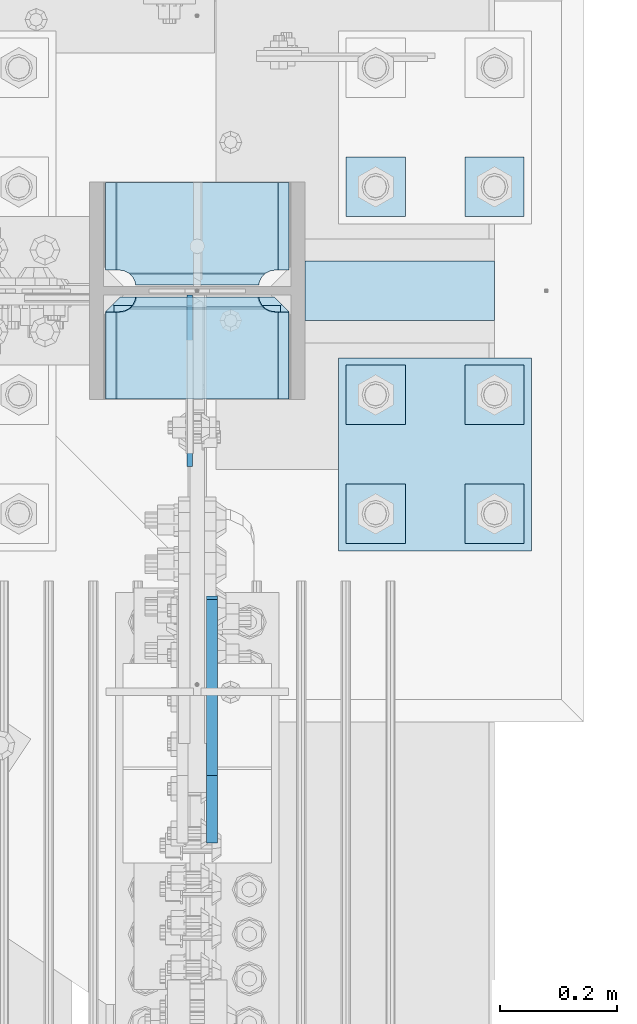
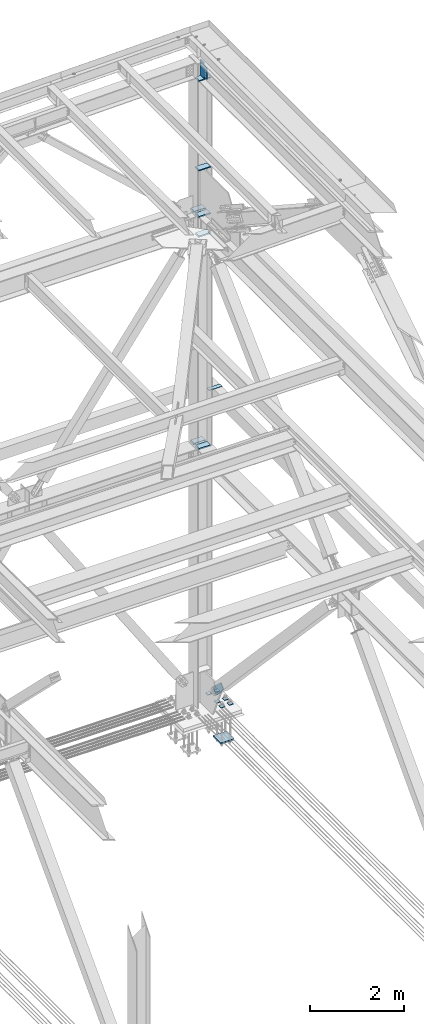
# One storey, part 3658 of 3843: 17 plates, 4 elements without a shape of their own.
"""IFC2X3 building model written with IfcOpenShell, lengths in millimetres."""

import ifcopenshell
import ifcopenshell.guid

model = None  # the IFC model being written
_history = None  # IfcOwnerHistory: only IFC2X3 demands one
_inside = {}  # id of a spatial element -> (the spatial element, [elements in it])
_under = {}  # id of a project, library or spatial element -> (it, [spatial elements below it])
_declared = {}  # id of a project -> (the project, [libraries it declares])
_typed = {}  # id of a type object -> (the type object, [elements of that type])
_made_of = {}  # id of a material, layer set ... -> (it, [elements and type objects made of it])


def new_model(schema):
    """Start an empty IFC model of exactly this schema.

    Asked for "IFC4X3", IfcOpenShell would pick the latest addendum, in which some entities
    have other attributes; the version numbers below select the first issue.
    IFC2X3 requires an IfcOwnerHistory on every rooted entity: one is made here for all.
    """
    global model, _history
    if schema == "IFC4X3":
        model = ifcopenshell.file(schema_version=(4, 3, 0, 0))
    else:
        model = ifcopenshell.file(schema=schema)
    _inside.clear()
    _under.clear()
    _declared.clear()
    _typed.clear()
    _made_of.clear()
    _history = None
    if model.schema == "IFC2X3":
        org = make("IfcOrganization", Name="unknown")
        user = make(
            "IfcPersonAndOrganization",
            ThePerson=make("IfcPerson", FamilyName="unknown"),
            TheOrganization=org,
        )
        app = make(
            "IfcApplication",
            ApplicationDeveloper=org,
            Version="unknown",
            ApplicationFullName="unknown",
            ApplicationIdentifier="unknown",
        )
        _history = make(
            "IfcOwnerHistory",
            OwningUser=user,
            OwningApplication=app,
            ChangeAction="ADDED",
            CreationDate=0,
        )
    return model


def make(cls, **values):
    """One entity of the class cls with the attributes given. An attribute that is None is left unset."""
    return model.create_entity(
        cls, **{name: value for name, value in values.items() if value is not None}
    )


def rooted(cls, **values):
    """An entity with a GlobalId (a new one), such as an element, a storey or a relation."""
    return make(cls, GlobalId=ifcopenshell.guid.new(), OwnerHistory=_history, **values)


def si_unit(unit_type, name, prefix=None):
    """IfcSIUnit, for example si_unit("LENGTHUNIT", "METRE", prefix="MILLI")."""
    return make("IfcSIUnit", UnitType=unit_type, Prefix=prefix, Name=name)


def assignment(units):
    """IfcUnitAssignment: the units of a project."""
    return None if units is None else make("IfcUnitAssignment", Units=units)


def point(xyz):
    """IfcCartesianPoint."""
    return None if xyz is None else make("IfcCartesianPoint", Coordinates=xyz)


def direction(xyz):
    """IfcDirection."""
    return None if xyz is None else make("IfcDirection", DirectionRatios=xyz)


def frame(location, z_axis=None, x_axis=None):
    """IfcAxis2Placement3D, a coordinate frame: its origin and axes. An axis left out is left unset."""
    return make(
        "IfcAxis2Placement3D",
        Location=point(location),
        Axis=direction(z_axis),
        RefDirection=direction(x_axis),
    )


def origin_with_axes():
    """The frame at (0, 0, 0) with the z axis (0, 0, 1) and the x axis (1, 0, 0) written out."""
    return frame((0.0, 0.0, 0.0), z_axis=(0.0, 0.0, 1.0), x_axis=(1.0, 0.0, 0.0))


def place(relative_to, where):
    """IfcLocalPlacement: puts the frame where relative to a parent placement (None: the world)."""
    return make(
        "IfcLocalPlacement", PlacementRelTo=relative_to, RelativePlacement=where
    )


def context(
    kind, dimensions, precision=None, world=None, true_north=None, identifier=None
):
    """IfcGeometricRepresentationContext, for example the 3D "Model" context."""
    return make(
        "IfcGeometricRepresentationContext",
        ContextIdentifier=identifier,
        ContextType=kind,
        CoordinateSpaceDimension=dimensions,
        Precision=precision,
        WorldCoordinateSystem=world,
        TrueNorth=true_north,
    )


def subcontext(parent, identifier, kind, view, scale=None):
    """IfcGeometricRepresentationSubContext, for example "Body" below "Model"."""
    return make(
        "IfcGeometricRepresentationSubContext",
        ContextIdentifier=identifier,
        ContextType=kind,
        ParentContext=parent,
        TargetScale=scale,
        TargetView=view,
    )


def project(units=None, contexts=None):
    """IfcProject with its units and contexts."""
    return rooted(
        "IfcProject",
        Name="project",
        RepresentationContexts=contexts,
        UnitsInContext=assignment(units),
    )


def spatial(cls, under=None, at=None, **own):
    """A site, building, storey or space (cls), placed at a placement, below another one or the project."""
    s = rooted(cls, ObjectPlacement=at, **own)
    if under is not None:
        _under.setdefault(under.id(), (under, []))[1].append(s)
    return s


def faces_of(points, faces, orient=None, outer=None):
    """IfcFace entities. A face is a list of loops; a loop is a list of indices into points, from 0.

    orient and outer hold one flag for each loop. By default every Orientation is true, the
    first loop of a face is its IfcFaceOuterBound and the others are IfcFaceBound.
    """
    made = []
    for i, loops in enumerate(faces):
        bounds = []
        for j, loop in enumerate(loops):
            is_outer = j == 0 if outer is None else outer[i][j]
            bounds.append(
                make(
                    "IfcFaceOuterBound" if is_outer else "IfcFaceBound",
                    Bound=make("IfcPolyLoop", Polygon=[points[k] for k in loop]),
                    Orientation=True if orient is None else orient[i][j],
                )
            )
        made.append(make("IfcFace", Bounds=bounds))
    return made


def faceted_brep(points, faces, orient=None, outer=None, voids=None):
    """IfcFacetedBrep: a solid bounded by flat faces; with voids (closed shells), ...WithVoids."""
    shared = [point(p) for p in points]
    hull = make("IfcClosedShell", CfsFaces=faces_of(shared, faces, orient, outer))
    if voids is None:
        return make("IfcFacetedBrep", Outer=hull)
    return make(
        "IfcFacetedBrepWithVoids",
        Outer=hull,
        Voids=[
            make(cls, CfsFaces=faces_of(shared, fs, o, b)) for cls, fs, o, b in voids
        ],
    )


def shape(context_of_items, identifier, shape_type, items):
    """IfcShapeRepresentation: the items that make up one representation, for example the "Body"."""
    return make(
        "IfcShapeRepresentation",
        ContextOfItems=context_of_items,
        RepresentationIdentifier=identifier,
        RepresentationType=shape_type,
        Items=items,
    )


def material(Name=None, Category=None):
    """IfcMaterial."""
    return make("IfcMaterial", Name=Name, Category=Category)


def made_of(thing, what):
    """Note that an element or type object is made of a material, layer set ...; save() writes the relation."""
    if what is not None:
        _made_of.setdefault(what.id(), (what, []))[1].append(thing)
    return thing


def type_object(cls, material=None, **own):
    """A type object (cls), such as IfcWallType, which elements share."""
    return made_of(rooted(cls, **own), material)


def element(
    cls,
    number,
    at=None,
    inside=None,
    cuts=None,
    type_object=None,
    material=None,
    context=None,
    identifier="Body",
    shape_type=None,
    held_by="IfcProductDefinitionShape",
    body=None,
    shapes=None,
    **own,
):
    """One element of the class cls, such as IfcWall. Its Tag is "e" and its number.

    at: its placement. inside: the storey or other place that contains it. cuts: it is an
    opening in that element (IfcRelVoidsElement). A single representation is given by context,
    identifier, shape_type and body (its items); several are given by shapes. held_by: the class
    of the entity that holds the representations. save() writes the other relations.
    """
    e = rooted(cls, Tag="e%d" % number, ObjectPlacement=at, **own)
    if body is not None:
        shapes = [shape(context, identifier, shape_type, body)]
    if shapes is not None:
        e.Representation = make(held_by, Representations=shapes)
    if inside is not None:
        _inside.setdefault(inside.id(), (inside, []))[1].append(e)
    if cuts is not None:
        rooted(
            "IfcRelVoidsElement", RelatingBuildingElement=cuts, RelatedOpeningElement=e
        )
    if type_object is not None:
        _typed.setdefault(type_object.id(), (type_object, []))[1].append(e)
    return made_of(e, material)


def aggregate(whole, parts):
    """IfcRelAggregates: a whole, such as a stair, and the parts it consists of."""
    return rooted("IfcRelAggregates", RelatingObject=whole, RelatedObjects=parts)


def save(model, path):
    """Write the relations noted so far, then the file.

    IfcRelAggregates (storeys below a building ...), IfcRelContainedInSpatialStructure (elements
    in a storey), IfcRelDefinesByType, IfcRelAssociatesMaterial and IfcRelDeclares: one each for
    every whole, place, type object, material and project.
    """
    for whole, parts in _under.values():
        aggregate(whole, parts)
    for where, things in _inside.values():
        rooted(
            "IfcRelContainedInSpatialStructure",
            RelatedElements=things,
            RelatingStructure=where,
        )
    for kind, things in _typed.values():
        rooted("IfcRelDefinesByType", RelatedObjects=things, RelatingType=kind)
    for what, things in _made_of.values():
        rooted("IfcRelAssociatesMaterial", RelatedObjects=things, RelatingMaterial=what)
    for by, libraries in _declared.values():
        rooted("IfcRelDeclares", RelatingContext=by, RelatedDefinitions=libraries)
    model.write(path)


model = new_model("IFC2X3")

# Units and contexts
model_context = context("Model", 3, precision=1e-05, world=origin_with_axes())
body_context = subcontext(model_context, "Body", "Model", "MODEL_VIEW")
ifc_project = project(units=[si_unit("LENGTHUNIT", "METRE", prefix="MILLI"), si_unit("AREAUNIT", "SQUARE_METRE"), si_unit("VOLUMEUNIT", "CUBIC_METRE"), si_unit("MASSUNIT", "GRAM", prefix="KILO"), si_unit("TIMEUNIT", "SECOND"), si_unit("PLANEANGLEUNIT", "RADIAN"), si_unit("SOLIDANGLEUNIT", "STERADIAN"), si_unit("THERMODYNAMICTEMPERATUREUNIT", "DEGREE_CELSIUS"), si_unit("LUMINOUSINTENSITYUNIT", "LUMEN")], contexts=[model_context])

# Site, building, storey
site_placement = place(None, origin_with_axes())
site = spatial("IfcSite", under=ifc_project, at=site_placement, CompositionType="ELEMENT")
building_placement = place(site_placement, origin_with_axes())
building = spatial("IfcBuilding", under=site, at=building_placement, Name="Undefined", CompositionType="ELEMENT")
storey_placement = place(building_placement, origin_with_axes())
storey = spatial("IfcBuildingStorey", under=building, at=storey_placement, Name="Undefined", CompositionType="ELEMENT", Elevation=0.0)

# Assembly, plate
assembly_1_placement = place(storey_placement, origin_with_axes())
assembly_1 = element("IfcElementAssembly", 1, at=assembly_1_placement, inside=storey, Name="PLATE", AssemblyPlace="NOTDEFINED", PredefinedType="RIGID_FRAME")
ifc_material_1 = material(Name="STEEL/A572-50")
plate_type_1 = type_object("IfcPlateType", PredefinedType="NOTDEFINED")
plate_1_placement = place(assembly_1_placement, frame((85832.950122492, 104508.3, 37749.1625), z_axis=(0.0, 1.0, 0.0), x_axis=(1.0, 0.0, 0.0)))
plate_1 = element("IfcPlate", 2, at=plate_1_placement, type_object=plate_type_1, material=ifc_material_1, Name="PLATE", context=body_context, shape_type="Brep", body=[
    faceted_brep([(0.0, -4.76249999999709, 0.0), (-0.000122492027003318, -4.76249999999709, 101.599998474121), (-0.000122492027003318, 4.76249999999709, 101.599998474121), (0.0, 4.76249999999709, 0.0), (323.849865722659, -4.76249999999709, 101.599998474121), (323.849865722659, 4.76249999999709, 101.599998474121), (323.849987792972, -4.76249999999709, -1.45519152283669e-11), (323.849987792972, 4.76249999999709, -1.45519152283669e-11)], [[[0, 1, 2, 3]], [[1, 4, 5, 2]], [[4, 6, 7, 5]], [[6, 0, 3, 7]], [[5, 7, 3, 2]], [[6, 4, 1, 0]]]),
])
aggregate(assembly_1, [plate_1])

# Assembly, plates
assembly_2_placement = place(storey_placement, origin_with_axes())
assembly_2 = element("IfcElementAssembly", 3, at=assembly_2_placement, inside=storey, Name="COLUMN", AssemblyPlace="NOTDEFINED", PredefinedType="RIGID_FRAME")
plate_type_2 = type_object("IfcPlateType", PredefinedType="NOTDEFINED")
plate_2_placement = place(assembly_2_placement, frame((85488.4625, 104566.24375, 42452.925), z_axis=(1.0, 0.0, 0.0), x_axis=(0.0, 1.0, 0.0)))
plate_2 = element("IfcPlate", 4, at=plate_2_placement, type_object=plate_type_2, material=ifc_material_1, Name="PLATE", context=body_context, shape_type="Brep", body=[
    faceted_brep([(16.7959640327026, 7.71646429280372, 270.56982732442), (21.5063709990791, 15.875, 275.280234290796), (21.5063709990791, 15.875, 45.3947535021725), (16.7959640327026, 7.71646429280372, 50.105160468549), (8.83016085001873, -6.0804942643299, 54.1639399157866), (3.17549995231093, -15.875, 55.0595502173092), (3.17549995231093, -15.875, 265.61543757566), (8.83016085001873, -6.0804942643299, 266.511047877182), (28.5750007629395, 15.875, 299.168629000924), (28.5750007629395, -15.875, 317.499500047692), (177.799999999999, -15.875, 317.499500047692), (177.799999999999, 15.875, 299.168629000924), (177.799999999999, 15.875, 21.5053709990898), (177.799999999999, -15.875, 3.17449995232164), (28.5750007629395, -15.875, 3.17449995232164), (28.5750007629395, 15.875, 21.5053709990898), (8.83016085001873, -15.875, 266.511047877182), (16.7959640327026, -15.875, 270.56982732442), (23.1176612314885, -15.875, 276.891524523206), (23.1176612314885, 15.875, 276.891524523206), (27.1764406787261, -15.875, 284.857327705889), (27.1764406787261, 15.875, 284.857327705889), (28.5750007629395, -15.875, 293.687488555908), (28.5750007629395, 15.875, 293.687488555908), (28.5750007629395, -15.875, 26.9874992370605), (28.5750007629395, 15.875, 26.9874992370605), (27.1764406787261, -15.875, 35.8176600870793), (27.1764406787261, 15.875, 35.8176600870793), (23.1176612314885, -15.875, 43.7834632697632), (23.1176612314885, 15.875, 43.7834632697632), (16.7959640327026, -15.875, 50.105160468549), (8.83016085001873, -15.875, 54.1639399157866)], [[[0, 1, 2, 3, 4, 5, 6, 7]], [[8, 9, 10, 11]], [[12, 13, 14, 15]], [[16, 7, 6]], [[16, 17, 0, 7]], [[17, 18, 19, 1, 0]], [[18, 20, 21, 19]], [[20, 22, 23, 21]], [[23, 22, 9, 8]], [[13, 12, 11, 10]], [[24, 25, 15, 14]], [[24, 26, 27, 25]], [[26, 28, 29, 27]], [[29, 28, 30, 3, 2]], [[30, 31, 4, 3]], [[31, 5, 4]], [[19, 21, 23, 8, 11, 12, 15, 25, 27, 29, 2, 1]], [[31, 30, 28, 26, 24, 14, 13, 10, 9, 22, 20, 18, 17, 16, 6, 5]]]),
])
plate_3_placement = place(assembly_2_placement, frame((85488.4625, 104374.15625, 41941.75), z_axis=(1.0, 0.0, 0.0), x_axis=(0.0, 1.0, 0.0)))
plate_3 = element("IfcPlate", 5, at=plate_3_placement, type_object=plate_type_2, material=ifc_material_1, Name="PLATE", context=body_context, shape_type="Brep", body=[
    faceted_brep([(161.004039019055, 7.71732501884981, 50.105160468549), (156.294129000918, 15.875, 45.3952504504123), (156.294129000918, 15.875, 275.279737342556), (161.004039019055, 7.71732501884981, 270.56982732442), (168.969842201739, -6.07963353828382, 266.511047877182), (174.625000047685, -15.875, 265.615370590487), (174.625000047685, -15.875, 55.0596294095158), (168.969842201739, -6.07963353828382, 54.1639399157866), (0.0, 15.875, 299.168629000924), (0.0, -15.875, 317.499500047692), (149.225002288818, -15.875, 317.499500047677), (149.225002288818, 15.875, 299.168629000909), (149.225002288818, 15.875, 21.5053709990752), (149.225002288818, -15.875, 3.17449995230709), (0.0, -15.875, 3.17449995232164), (0.0, 15.875, 21.5053709990898), (149.225002288818, -15.875, 293.687488555908), (149.225002288818, 15.875, 293.687488555908), (150.623562373032, -15.875, 284.857327705889), (150.623562373032, 15.875, 284.857327705889), (154.682341820269, -15.875, 276.891524523206), (154.682341820269, 15.875, 276.891524523206), (161.004039019055, -15.875, 270.56982732442), (168.969842201739, -15.875, 266.511047877182), (168.969842201739, -15.875, 54.1639399157866), (161.004039019055, -15.875, 50.105160468549), (154.682341820269, -15.875, 43.7834632697632), (154.682341820269, 15.875, 43.7834632697632), (150.623562373032, -15.875, 35.8176600870793), (150.623562373032, 15.875, 35.8176600870793), (149.225002288818, -15.875, 26.9874992370605), (149.225002288818, 15.875, 26.9874992370605)], [[[0, 1, 2, 3, 4, 5, 6, 7]], [[8, 9, 10, 11]], [[12, 13, 14, 15]], [[9, 8, 15, 14]], [[16, 17, 11, 10]], [[16, 18, 19, 17]], [[18, 20, 21, 19]], [[21, 20, 22, 3, 2]], [[22, 23, 4, 3]], [[23, 5, 4]], [[24, 7, 6]], [[24, 25, 0, 7]], [[25, 26, 27, 1, 0]], [[26, 28, 29, 27]], [[28, 30, 31, 29]], [[31, 30, 13, 12]], [[27, 29, 31, 12, 15, 8, 11, 17, 19, 21, 2, 1]], [[13, 30, 28, 26, 25, 24, 6, 5, 23, 22, 20, 18, 16, 10, 9, 14]]]),
])
plate_4_placement = place(assembly_2_placement, frame((85488.4625, 104374.15625, 42452.925), z_axis=(1.0, 0.0, 0.0), x_axis=(0.0, 1.0, 0.0)))
plate_4 = element("IfcPlate", 6, at=plate_4_placement, type_object=plate_type_2, material=ifc_material_1, Name="PLATE", context=body_context, shape_type="Brep", body=[
    faceted_brep([(161.004039019055, 7.71732501884981, 50.105160468549), (156.294129000918, 15.875, 45.3952504504123), (156.294129000918, 15.875, 275.279737342556), (161.004039019055, 7.71732501884981, 270.56982732442), (168.969842201739, -6.07963353828382, 266.511047877182), (174.625000047685, -15.875, 265.615370590487), (174.625000047685, -15.875, 55.0596294095158), (168.969842201739, -6.07963353828382, 54.1639399157866), (0.0, 15.875, 299.168629000924), (0.0, -15.875, 317.499500047692), (149.225002288818, -15.875, 317.499500047677), (149.225002288818, 15.875, 299.168629000909), (149.225002288818, 15.875, 21.5053709990752), (149.225002288818, -15.875, 3.17449995230709), (0.0, -15.875, 3.17449995232164), (0.0, 15.875, 21.5053709990898), (149.225002288818, -15.875, 293.687488555908), (149.225002288818, 15.875, 293.687488555908), (150.623562373032, -15.875, 284.857327705889), (150.623562373032, 15.875, 284.857327705889), (154.682341820269, -15.875, 276.891524523206), (154.682341820269, 15.875, 276.891524523206), (161.004039019055, -15.875, 270.56982732442), (168.969842201739, -15.875, 266.511047877182), (168.969842201739, -15.875, 54.1639399157866), (161.004039019055, -15.875, 50.105160468549), (154.682341820269, -15.875, 43.7834632697632), (154.682341820269, 15.875, 43.7834632697632), (150.623562373032, -15.875, 35.8176600870793), (150.623562373032, 15.875, 35.8176600870793), (149.225002288818, -15.875, 26.9874992370605), (149.225002288818, 15.875, 26.9874992370605)], [[[0, 1, 2, 3, 4, 5, 6, 7]], [[8, 9, 10, 11]], [[12, 13, 14, 15]], [[9, 8, 15, 14]], [[16, 17, 11, 10]], [[16, 18, 19, 17]], [[18, 20, 21, 19]], [[21, 20, 22, 3, 2]], [[22, 23, 4, 3]], [[23, 5, 4]], [[24, 7, 6]], [[24, 25, 0, 7]], [[25, 26, 27, 1, 0]], [[26, 28, 29, 27]], [[28, 30, 31, 29]], [[31, 30, 13, 12]], [[27, 29, 31, 12, 15, 8, 11, 17, 19, 21, 2, 1]], [[13, 30, 28, 26, 25, 24, 6, 5, 23, 22, 20, 18, 16, 10, 9, 14]]]),
])
plate_type_3 = type_object("IfcPlateType", PredefinedType="NOTDEFINED")
plate_5_placement = place(assembly_2_placement, frame((85490.05, 104374.15625, 45988.2875), z_axis=(1.0, 0.0, 0.0), x_axis=(0.0, 1.0, 0.0)))
plate_5 = element("IfcPlate", 7, at=plate_5_placement, type_object=plate_type_3, material=ifc_material_1, Name="PLATE", context=body_context, shape_type="Brep", body=[
    faceted_brep([(161.004039019055, 9.3046957865372, 50.105160468549), (158.127215665096, 14.2874999999985, 47.2283371145895), (158.127215665096, 14.2874999999985, 270.27166288541), (161.004039019055, 9.3046957865372, 267.394839531451), (168.969842201739, -4.49248004895344, 263.336060084213), (174.625000047683, -14.2874999999985, 262.440371073826), (174.625000047685, -14.2874999999985, 55.0596294095158), (168.969842201739, -4.49248004895344, 54.1639399157866), (0.0, 14.2874999999985, 297.827215665093), (0.0, -14.2874999999985, 314.325000047669), (149.225002288818, -14.2874999999985, 314.325000047669), (149.225002288818, 14.2874999999985, 297.827215665093), (149.225002288818, 14.2874999999985, 19.6727843348781), (149.225002288818, -14.2874999999985, 3.17499995230173), (0.0, -14.2874999999985, 3.17499995230173), (0.0, 14.2874999999985, 19.6727843348781), (149.225002288818, -14.2874999999985, 290.512500762939), (149.225002288818, 14.2874999999985, 290.512500762939), (150.623562373032, -14.2874999999985, 281.682339912921), (150.623562373032, 14.2874999999985, 281.682339912921), (154.682341820269, -14.2874999999985, 273.716536730237), (154.682341820269, 14.2874999999985, 273.716536730237), (161.004039019055, -14.2874999999985, 267.394839531451), (168.969842201739, -14.2874999999985, 263.336060084213), (168.969842201739, -14.2874999999985, 54.1639399157866), (161.004039019055, -14.2874999999985, 50.105160468549), (154.682341820269, -14.2874999999985, 43.7834632697632), (154.682341820269, 14.2874999999985, 43.7834632697632), (150.623562373032, -14.2874999999985, 35.8176600870793), (150.623562373032, 14.2874999999985, 35.8176600870793), (149.225002288818, -14.2874999999985, 26.9874992370605), (149.225002288818, 14.2874999999985, 26.9874992370605)], [[[0, 1, 2, 3, 4, 5, 6, 7]], [[8, 9, 10, 11]], [[12, 13, 14, 15]], [[15, 14, 9, 8]], [[16, 17, 11, 10]], [[16, 18, 19, 17]], [[18, 20, 21, 19]], [[21, 20, 22, 3, 2]], [[22, 23, 4, 3]], [[23, 5, 4]], [[24, 7, 6]], [[24, 25, 0, 7]], [[25, 26, 27, 1, 0]], [[26, 28, 29, 27]], [[28, 30, 31, 29]], [[31, 30, 13, 12]], [[27, 29, 31, 12, 15, 8, 11, 17, 19, 21, 2, 1]], [[13, 30, 28, 26, 25, 24, 6, 5, 23, 22, 20, 18, 16, 10, 9, 14]]]),
])
plate_type_4 = type_object("IfcPlateType", PredefinedType="NOTDEFINED")
plate_6_placement = place(assembly_2_placement, frame((85809.1375, 104744.04375, 36418.8375), z_axis=(-1.0, 0.0, 0.0), x_axis=(0.0, -1.0, 0.0)))
plate_6 = element("IfcPlate", 8, at=plate_6_placement, type_object=plate_type_4, material=ifc_material_1, Name="PLATE", context=body_context, shape_type="Brep", body=[
    faceted_brep([(161.004039019055, 6.12926429974323, 50.105160468549), (154.682341820269, 17.0787650381244, 43.7834632697632), (154.460792336729, 17.4625000000015, 43.3486479258863), (154.460792336729, 17.4625000000015, 277.326339867082), (154.682341820269, 17.0787650381244, 276.891524523206), (161.004039019055, 6.1292642997505, 270.56982732442), (168.969842201739, -7.66791153574013, 266.511047877182), (174.624750047686, -17.4625000000015, 265.615410186598), (174.624750047686, -17.4625000000015, 55.0595898134052), (168.969842201739, -7.66791153574013, 54.1639399157866), (0.0, 17.4625000000015, 297.335542336732), (0.0, -17.4625000000015, 317.499500047692), (149.225002288818, -17.4625000000015, 317.499500047663), (149.225002288818, 17.4625000000015, 297.335542336703), (149.225002288818, 17.4625000000015, 23.3394576632563), (149.225002288818, -17.4625000000015, 3.17549995229638), (0.0, -17.4625000000015, 3.17549995229638), (0.0, 17.4625000000015, 23.3394576632563), (149.225002288818, -17.4625000000015, 293.687488555908), (149.225002288818, 17.4625000000015, 293.687488555908), (150.623562373032, -17.4625000000015, 284.857327705889), (150.623562373032, 17.4625000000015, 284.857327705889), (154.682341820269, -17.4625000000015, 276.891524523206), (161.004039019055, -17.4625000000015, 270.56982732442), (168.969842201739, -17.4625000000015, 266.511047877182), (168.969842201739, -17.4625000000015, 54.1639399157866), (161.004039019055, -17.4625000000015, 50.105160468549), (154.682341820269, -17.4625000000015, 43.7834632697632), (150.623562373032, -17.4625000000015, 35.8176600870793), (150.623562373032, 17.4625000000015, 35.8176600870793), (149.225002288818, -17.4625000000015, 26.9874992370605), (149.225002288818, 17.4625000000015, 26.9874992370605)], [[[0, 1, 2, 3, 4, 5, 6, 7, 8, 9]], [[10, 11, 12, 13]], [[14, 15, 16, 17]], [[17, 16, 11, 10]], [[18, 19, 13, 12]], [[18, 20, 21, 19]], [[21, 20, 22, 4, 3]], [[22, 23, 5, 4]], [[23, 24, 6, 5]], [[24, 7, 6]], [[25, 9, 8]], [[25, 26, 0, 9]], [[26, 27, 1, 0]], [[27, 28, 29, 2, 1]], [[28, 30, 31, 29]], [[31, 30, 15, 14]], [[29, 31, 14, 17, 10, 13, 19, 21, 3, 2]], [[15, 30, 28, 27, 26, 25, 8, 7, 24, 23, 22, 20, 18, 12, 11, 16]]]),
])
plate_7_placement = place(assembly_2_placement, frame((85488.4625, 104374.15625, 36418.8375), z_axis=(1.0, 0.0, 0.0), x_axis=(0.0, 1.0, 0.0)))
plate_7 = element("IfcPlate", 9, at=plate_7_placement, type_object=plate_type_4, material=ifc_material_1, Name="PLATE", context=body_context, shape_type="Brep", body=[
    faceted_brep([(160.070930155271, 7.74588927352306, 49.8019750199746), (154.461042336727, 17.4625000000015, 44.1920872014452), (154.461042336727, 17.4625000000015, 276.482900591524), (160.070930155271, 7.74588927352306, 270.873012772994), (168.479277841048, -6.81779612594983, 266.588745638888), (174.625000047687, -17.4625000000015, 265.615358866795), (174.625000047687, -17.4625000000015, 55.0596289261739), (168.479277841048, -6.81779612594983, 54.0862421540805), (147.637502670288, 17.4625000000015, 23.3384576632816), (147.637502670288, -17.4625000000015, 3.17449995232164), (0.0, -17.4625000000015, 3.17449995232164), (0.0, 17.4625000000015, 23.3384576632816), (0.0, 17.4625000000015, 297.335542336732), (0.0, -17.4625000000015, 317.499500047692), (147.637502670288, -17.4625000000015, 317.499500047692), (147.637502670288, 17.4625000000015, 297.335542336732), (147.637502670288, -17.4625000000015, 295.274988174438), (147.637502670288, 17.4625000000015, 295.274988174438), (149.113760516208, -17.4625000000015, 285.954262963729), (149.113760516208, 17.4625000000015, 285.954262963729), (153.398027650313, -17.4625000000015, 277.545915277951), (153.398027650313, 17.4625000000015, 277.545915277951), (160.070930155271, -17.4625000000015, 270.873012772994), (168.479277841048, -17.4625000000015, 266.588745638888), (168.479277841048, -17.4625000000015, 54.0862421540805), (160.070930155271, -17.4625000000015, 49.8019750199746), (153.398027650313, -17.4625000000015, 43.1290725150175), (153.398027650313, 17.4625000000015, 43.1290725150175), (149.113760516208, -17.4625000000015, 34.7207248292398), (149.113760516208, 17.4625000000015, 34.7207248292398), (147.637502670288, -17.4625000000015, 25.3999996185303), (147.637502670288, 17.4625000000015, 25.3999996185303)], [[[0, 1, 2, 3, 4, 5, 6, 7]], [[8, 9, 10, 11]], [[12, 13, 14, 15]], [[13, 12, 11, 10]], [[16, 17, 15, 14]], [[16, 18, 19, 17]], [[18, 20, 21, 19]], [[21, 20, 22, 3, 2]], [[22, 23, 4, 3]], [[23, 5, 4]], [[24, 7, 6]], [[24, 25, 0, 7]], [[25, 26, 27, 1, 0]], [[26, 28, 29, 27]], [[28, 30, 31, 29]], [[31, 30, 9, 8]], [[27, 29, 31, 8, 11, 12, 15, 17, 19, 21, 2, 1]], [[9, 30, 28, 26, 25, 24, 6, 5, 23, 22, 20, 18, 16, 14, 13, 10]]]),
])

assembly_3_placement = place(storey_placement, origin_with_axes())
assembly_3 = element("IfcElementAssembly", 10, at=assembly_3_placement, inside=storey, Name="TEMPLATE", AssemblyPlace="NOTDEFINED", PredefinedType="RIGID_FRAME")
plate_type_5 = type_object("IfcPlateType", PredefinedType="NOTDEFINED")
plate_8_placement = place(assembly_3_placement, frame((86106.0, 104228.9, 29698.95), z_axis=(0.0, -1.0, 0.0), x_axis=(1.0, 0.0, 0.0)))
plate_8 = element("IfcPlate", 11, at=plate_8_placement, type_object=plate_type_5, material=ifc_material_1, Name="Washer Plate", context=body_context, shape_type="Brep", body=[
    faceted_brep([(0.0, -6.3499999046162, 0.0), (-1.67347025126219e-10, -6.35000000000582, 101.600000000151), (-1.67347025126219e-10, 6.35000000000582, 101.600000000151), (7.27595761418343e-12, 6.3499999046162, 0.0), (101.599998474121, -6.34999999999854, 101.599998474121), (101.599998474121, 6.34999999999854, 101.599998474121), (101.6, -6.34999999999854, 0.0), (101.6, 6.34999999999854, 0.0)], [[[0, 1, 2, 3]], [[1, 4, 5, 2]], [[4, 6, 7, 5]], [[6, 0, 3, 7]], [[5, 7, 3, 2]], [[6, 4, 1, 0]]]),
])
plate_9_placement = place(assembly_3_placement, frame((86106.0, 104432.1, 29698.95), z_axis=(0.0, -1.0, 0.0), x_axis=(1.0, 0.0, 0.0)))
plate_9 = element("IfcPlate", 12, at=plate_9_placement, type_object=plate_type_5, material=ifc_material_1, Name="Washer Plate", context=body_context, shape_type="Brep", body=[
    faceted_brep([(0.0, -6.3499999046162, 0.0), (-1.67347025126219e-10, -6.35000000000582, 101.600000000151), (-1.67347025126219e-10, 6.35000000000582, 101.600000000151), (7.27595761418343e-12, 6.3499999046162, 0.0), (101.599998474121, -6.34999999999854, 101.599998474121), (101.599998474121, 6.34999999999854, 101.599998474121), (101.6, -6.34999999999854, 0.0), (101.6, 6.34999999999854, 0.0)], [[[0, 1, 2, 3]], [[1, 4, 5, 2]], [[4, 6, 7, 5]], [[6, 0, 3, 7]], [[5, 7, 3, 2]], [[6, 4, 1, 0]]]),
])
plate_10_placement = place(assembly_3_placement, frame((86106.0, 104787.7, 29698.95), z_axis=(0.0, -1.0, 0.0), x_axis=(1.0, 0.0, 0.0)))
plate_10 = element("IfcPlate", 13, at=plate_10_placement, type_object=plate_type_5, material=ifc_material_1, Name="Washer Plate", context=body_context, shape_type="Brep", body=[
    faceted_brep([(0.0, -6.3499999046162, 0.0), (-1.67347025126219e-10, -6.35000000000582, 101.600000000151), (-1.67347025126219e-10, 6.35000000000582, 101.600000000151), (7.27595761418343e-12, 6.3499999046162, 0.0), (101.599998474121, -6.34999999999854, 101.599998474121), (101.599998474121, 6.34999999999854, 101.599998474121), (101.6, -6.34999999999854, 0.0), (101.6, 6.34999999999854, 0.0)], [[[0, 1, 2, 3]], [[1, 4, 5, 2]], [[4, 6, 7, 5]], [[6, 0, 3, 7]], [[5, 7, 3, 2]], [[6, 4, 1, 0]]]),
])
plate_11_placement = place(assembly_3_placement, frame((85902.8, 104228.9, 29698.95), z_axis=(0.0, -1.0, 0.0), x_axis=(1.0, 0.0, 0.0)))
plate_11 = element("IfcPlate", 14, at=plate_11_placement, type_object=plate_type_5, material=ifc_material_1, Name="Washer Plate", context=body_context, shape_type="Brep", body=[
    faceted_brep([(0.0, -6.3499999046162, 0.0), (-1.67347025126219e-10, -6.35000000000582, 101.600000000151), (-1.67347025126219e-10, 6.35000000000582, 101.600000000151), (7.27595761418343e-12, 6.3499999046162, 0.0), (101.599998474121, -6.34999999999854, 101.599998474121), (101.599998474121, 6.34999999999854, 101.599998474121), (101.6, -6.34999999999854, 0.0), (101.6, 6.34999999999854, 0.0)], [[[0, 1, 2, 3]], [[1, 4, 5, 2]], [[4, 6, 7, 5]], [[6, 0, 3, 7]], [[5, 7, 3, 2]], [[6, 4, 1, 0]]]),
])
plate_12_placement = place(assembly_3_placement, frame((85902.8, 104432.1, 29698.95), z_axis=(0.0, -1.0, 0.0), x_axis=(1.0, 0.0, 0.0)))
plate_12 = element("IfcPlate", 15, at=plate_12_placement, type_object=plate_type_5, material=ifc_material_1, Name="Washer Plate", context=body_context, shape_type="Brep", body=[
    faceted_brep([(0.0, -6.3499999046162, 0.0), (-1.67347025126219e-10, -6.35000000000582, 101.600000000151), (-1.67347025126219e-10, 6.35000000000582, 101.600000000151), (7.27595761418343e-12, 6.3499999046162, 0.0), (101.599998474121, -6.34999999999854, 101.599998474121), (101.599998474121, 6.34999999999854, 101.599998474121), (101.6, -6.34999999999854, 0.0), (101.6, 6.34999999999854, 0.0)], [[[0, 1, 2, 3]], [[1, 4, 5, 2]], [[4, 6, 7, 5]], [[6, 0, 3, 7]], [[5, 7, 3, 2]], [[6, 4, 1, 0]]]),
])
plate_13_placement = place(assembly_3_placement, frame((85902.8, 104787.7, 29698.95), z_axis=(0.0, -1.0, 0.0), x_axis=(1.0, 0.0, 0.0)))
plate_13 = element("IfcPlate", 16, at=plate_13_placement, type_object=plate_type_5, material=ifc_material_1, Name="Washer Plate", context=body_context, shape_type="Brep", body=[
    faceted_brep([(0.0, -6.3499999046162, 0.0), (-1.67347025126219e-10, -6.35000000000582, 101.600000000151), (-1.67347025126219e-10, 6.35000000000582, 101.600000000151), (7.27595761418343e-12, 6.3499999046162, 0.0), (101.599998474121, -6.34999999999854, 101.599998474121), (101.599998474121, 6.34999999999854, 101.599998474121), (101.6, -6.34999999999854, 0.0), (101.6, 6.34999999999854, 0.0)], [[[0, 1, 2, 3]], [[1, 4, 5, 2]], [[4, 6, 7, 5]], [[6, 0, 3, 7]], [[5, 7, 3, 2]], [[6, 4, 1, 0]]]),
])

# Assembly, plate
assembly_4_placement = place(storey_placement, origin_with_axes())
assembly_4 = element("IfcElementAssembly", 17, at=assembly_4_placement, inside=storey, AssemblyPlace="NOTDEFINED", PredefinedType="RIGID_FRAME")
ifc_material_2 = material(Name="STEEL/A36")
plate_type_6 = type_object("IfcPlateType", PredefinedType="NOTDEFINED")
plate_14_placement = place(assembly_4_placement, frame((85674.2, 103731.246167624, 30687.9771468618), z_axis=(0.0, -0.72828277798531, -0.68527672898618), x_axis=(0.0, 0.685276728986183, -0.728282777985308)))
plate_14 = element("IfcPlate", 18, at=plate_14_placement, type_object=plate_type_6, material=ifc_material_2, context=body_context, shape_type="Brep", body=[
    faceted_brep([(0.0, -9.52500000000146, 0.0), (1.71894498635083e-09, -9.52499999999418, 158.39421297863), (1.71894498635083e-09, 9.52499999999418, 158.39421297863), (0.0, 9.52500000000146, 0.0), (69.8500000010408, -9.52499999999418, 158.394212979103), (69.8500000010408, 9.52499999999418, 158.394212979103), (171.450000002631, -9.52499999999418, 176.034606488582), (171.450000002631, 9.52499999999418, 176.034606488582), (390.129297671807, -9.52499999999418, 176.034606487716), (390.129297671807, 9.52499999999418, 176.034606487716), (427.187405137312, -9.52499999999418, 168.663290600991), (427.187405137312, 9.52499999999418, 168.663290600991), (458.60375167372, -9.52499999999418, 147.671558963724), (458.60375167372, 9.52499999999418, 147.671558963724), (479.59548331075, -9.52499999999418, 116.255212427161), (479.59548331075, 9.52499999999418, 116.255212427161), (486.966799197198, -9.52499999999418, 79.1971080138683), (486.966799197198, 9.52499999999418, 79.1971080138683), (479.595483310488, -9.52499999999418, 42.1390005483336), (479.595483310488, 9.52499999999418, 42.1390005483336), (458.603751673207, -9.52499999999418, 10.7226540119082), (458.603751673207, 9.52499999999418, 10.7226540119082), (427.18740513661, -9.52499999999418, -10.2690776251402), (427.18740513661, 9.52499999999418, -10.2690776251402), (390.129299195723, -9.52499999999418, -17.6403935115741), (390.129299195723, 9.52499999999418, -17.6403935115741), (171.450000001962, -9.52499999999418, -17.6403935107155), (171.450000001962, 9.52499999999418, -17.6403935107155), (69.8499999979995, -9.52499999999418, -4.00177668780088e-10), (69.8499999979995, 9.52499999999418, -4.00177668780088e-10)], [[[0, 1, 2, 3]], [[1, 4, 5, 2]], [[4, 6, 7, 5]], [[6, 8, 9, 7]], [[8, 10, 11, 9]], [[10, 12, 13, 11]], [[12, 14, 15, 13]], [[14, 16, 17, 15]], [[16, 18, 19, 17]], [[18, 20, 21, 19]], [[20, 22, 23, 21]], [[22, 24, 25, 23]], [[24, 26, 27, 25]], [[26, 28, 29, 27]], [[28, 0, 3, 29]], [[5, 7, 9, 11, 13, 15, 17, 19, 21, 23, 25, 27, 29, 3, 2]], [[28, 26, 24, 22, 20, 18, 16, 14, 12, 10, 8, 6, 4, 1, 0]]]),
])
aggregate(assembly_4, [plate_14])

# Plate
plate_type_7 = type_object("IfcPlateType", PredefinedType="NOTDEFINED")
plate_15_placement = place(assembly_2_placement, frame((85809.1375, 104374.1563, 43660.9107679332), z_axis=(-1.0, 0.0, 0.0), x_axis=(0.0, 1.0, 0.0)))
plate_15 = element("IfcPlate", 19, at=plate_15_placement, type_object=plate_type_7, material=ifc_material_1, Name="PLATE", context=body_context, shape_type="Brep", body=[
    faceted_brep([(0.0, -12.6999999999971, 302.834803430524), (0.0, 12.6999999999971, 317.499500047692), (0.0, 12.6999999999971, 3.17449995232164), (0.0, -12.6999999999971, 17.83919656949), (149.225449952311, 12.6999999999971, 317.499500047692), (174.624700047687, 12.6999999999971, 292.100249952317), (174.624700047687, 12.6999999999971, 28.5747500476864), (149.224449952322, 12.6999999999971, 3.17449995232164), (161.924575014753, -9.29726220098382, 15.8746250147524), (159.960003430519, -12.6999999999971, 17.83919656949), (159.960003430519, -12.6999999999971, 302.834803430524), (161.925075014762, -9.29639617558132, 304.799874985241)], [[[0, 1, 2, 3]], [[4, 5, 6, 7, 2, 1]], [[3, 2, 7, 8, 9]], [[0, 3, 9, 10]], [[4, 1, 0, 10, 11]], [[4, 11, 5]], [[10, 9, 8, 6, 5, 11]], [[7, 6, 8]]]),
])

plate_type_8 = type_object("IfcPlateType", PredefinedType="NOTDEFINED")
plate_16_placement = place(assembly_2_placement, frame((85636.0995000839, 104551.95625, 46021.625), z_axis=(0.0, -0.707106781186682, 0.707106781186413), x_axis=(0.0, -0.707106781186548, -0.707106781186548)))
plate_16 = element("IfcPlate", 20, at=plate_16_placement, type_object=plate_type_8, material=ifc_material_1, Name="PLATE", context=body_context, shape_type="Brep", body=[
    faceted_brep([(0.0, -4.76249999999709, 0.0), (-273.897811691269, -4.76249999999709, 273.897811691328), (-273.897811691269, 4.76249999999709, 273.897811691328), (0.0, 4.76249999999709, 0.0), (-273.897811691131, -4.76249999999709, 300.83858005454), (-273.897811691131, 4.76249999999709, 300.83858005454), (-161.644610177136, -4.76249999999709, 413.09178156851), (-161.644610177136, 4.76249999999709, 413.09178156851), (-132.458777648957, -4.76249999999709, 383.905949040323), (-132.458777648957, 4.76249999999709, 383.905949040323), (-128.338601180818, -4.76249999999709, 381.152935139853), (-128.338601180818, 4.76249999999709, 381.152935139853), (-123.478521662786, -4.76249999999709, 380.186205217266), (-123.478521662786, 4.76249999999709, 380.186205217266), (-118.618442144754, -4.76249999999709, 381.152935139853), (-118.618442144754, 4.76249999999709, 381.152935139853), (-114.498265676601, -4.76249999999709, 383.90594904032), (-114.498265676601, 4.76249999999709, 383.90594904032), (-42.0949505651442, -4.76249999999709, 456.309264151772), (-42.0949505651442, 4.76249999999709, 456.309264151772), (182.411452460481, -4.76249999999709, 231.802861126107), (182.411452460481, 4.76249999999709, 231.802861126107), (110.008137349017, -4.76249999999709, 159.399546014654), (110.008137349017, 4.76249999999709, 159.399546014654), (107.255123448544, -4.76249999999709, 155.279369546512), (107.255123448544, 4.76249999999709, 155.279369546512), (106.288393525967, -4.76249999999709, 150.41929002848), (106.288393525967, 4.76249999999709, 150.41929002848), (107.255123448551, -4.76249999999709, 145.559210510441), (107.255123448551, 4.76249999999709, 145.559210510441), (110.008137349017, -4.76249999999709, 141.439034042298), (110.008137349017, 4.76249999999709, 141.439034042298), (139.193969877184, -4.76249999999709, 112.253201514119), (139.193969877184, 4.76249999999709, 112.253201514119), (26.9407683631998, -4.76249999999709, 1.30967237055302e-10), (26.9407683631998, 4.76249999999709, 1.30967237055302e-10)], [[[0, 1, 2, 3]], [[1, 4, 5, 2]], [[4, 6, 7, 5]], [[6, 8, 9, 7]], [[8, 10, 11, 9]], [[10, 12, 13, 11]], [[12, 14, 15, 13]], [[14, 16, 17, 15]], [[16, 18, 19, 17]], [[18, 20, 21, 19]], [[20, 22, 23, 21]], [[22, 24, 25, 23]], [[24, 26, 27, 25]], [[26, 28, 29, 27]], [[28, 30, 31, 29]], [[30, 32, 33, 31]], [[32, 34, 35, 33]], [[34, 0, 3, 35]], [[5, 7, 9, 11, 13, 15, 17, 19, 21, 23, 25, 27, 29, 31, 33, 35, 3, 2]], [[34, 32, 30, 28, 26, 24, 22, 20, 18, 16, 14, 12, 10, 8, 6, 4, 1, 0]]]),
])

aggregate(assembly_2, [plate_6, plate_15, plate_2, plate_3, plate_4, plate_5, plate_16, plate_7])

plate_type_9 = type_object("IfcPlateType", PredefinedType="NOTDEFINED")
plate_17_placement = place(assembly_3_placement, frame((86220.3, 104114.599996948, 28784.55), z_axis=(-1.0, 0.0, 0.0), x_axis=(0.0, 1.0, 0.0)))
plate_17 = element("IfcPlate", 21, at=plate_17_placement, type_object=plate_type_9, material=ifc_material_1, Name="PLATE", context=body_context, shape_type="Brep", body=[
    faceted_brep([(0.0, -19.0500000000029, 0.0), (0.0, -19.0499999999993, 330.200012207031), (0.0, 19.0499999999993, 330.200012207031), (0.0, 19.0500000000029, 0.0), (330.200012207031, -19.0499999999993, 330.200012207031), (330.200012207031, 19.0499999999993, 330.200012207031), (330.200012207031, -19.0499999999993, 0.0), (330.200012207031, 19.0499999999993, 0.0)], [[[0, 1, 2, 3]], [[1, 4, 5, 2]], [[4, 6, 7, 5]], [[6, 0, 3, 7]], [[5, 7, 3, 2]], [[6, 4, 1, 0]]]),
])

aggregate(assembly_3, [plate_17, plate_8, plate_9, plate_10, plate_11, plate_12, plate_13])

save(model, "model.ifc")
